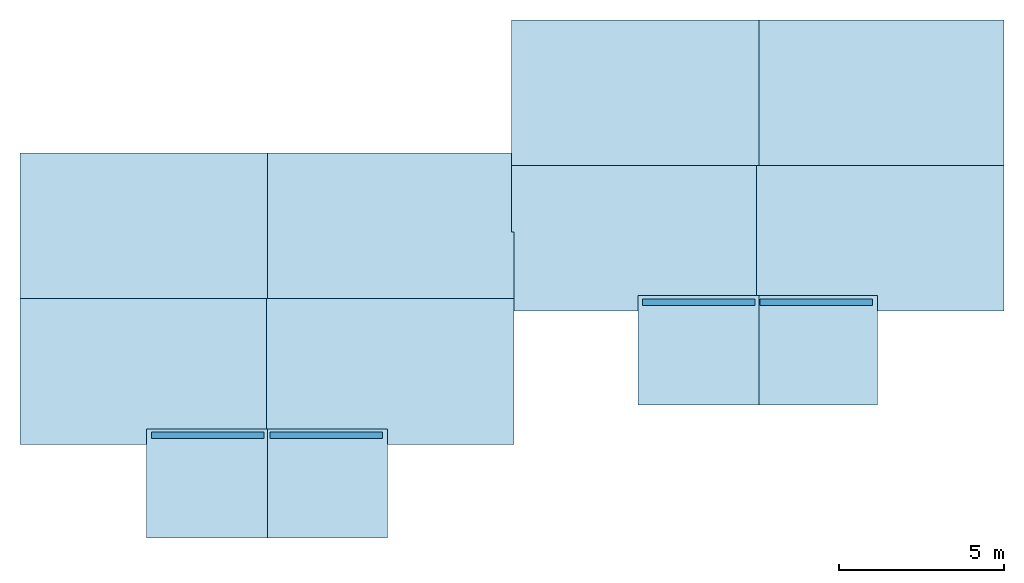
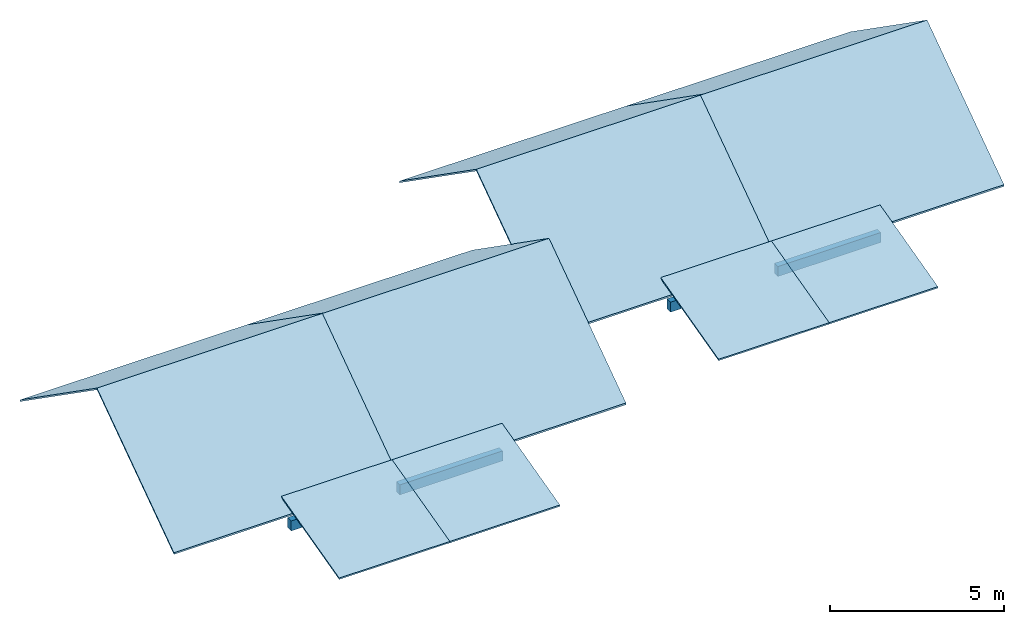
# One storey: 12 slabs, 4 beams, 8 elements without a shape of their own.
"""IFC2X3 building model written with IfcOpenShell, lengths in metres."""

from ifc_helpers import new_model, entity, si_unit, converted_unit, derived_unit, money_unit, direction, frame, frame_2d, origin_with_axes, place, context, subcontext, project, spatial, polyline, rectangle, outline, extrude, material, layer, layer_set, layer_usage, type_object, element, aggregate, save


model = new_model("IFC2X3")

# Units and contexts
model_context = context("Model", 3, precision=1e-05, world=origin_with_axes(), true_north=direction((0.0, 1.0)))
body_context = subcontext(model_context, "Body", "Model", "MODEL_VIEW")
ifc_project = project(units=[si_unit("LENGTHUNIT", "METRE"), si_unit("AREAUNIT", "SQUARE_METRE"), si_unit("VOLUMEUNIT", "CUBIC_METRE"), converted_unit("PLANEANGLEUNIT", "DEGREE", entity("IfcPlaneAngleMeasure", 0.0174532925199), si_unit("PLANEANGLEUNIT", "RADIAN"), dimensions=[0, 0, 0, 0, 0, 0, 0]), si_unit("SOLIDANGLEUNIT", "STERADIAN"), money_unit("CHF"), converted_unit("TIMEUNIT", "Year", entity("IfcTimeMeasure", 31556926.0), si_unit("TIMEUNIT", "SECOND"), dimensions=[0, 0, 1, 0, 0, 0, 0]), si_unit("MASSUNIT", "GRAM", prefix="KILO"), si_unit("THERMODYNAMICTEMPERATUREUNIT", "DEGREE_CELSIUS"), si_unit("LUMINOUSINTENSITYUNIT", "LUMEN"), si_unit("ENERGYUNIT", "JOULE", prefix="MEGA"), derived_unit("THERMALCONDUCTANCEUNIT", [(si_unit("POWERUNIT", "WATT"), 1), (si_unit("LENGTHUNIT", "METRE"), -1), (si_unit("THERMODYNAMICTEMPERATUREUNIT", "KELVIN"), -1)]), derived_unit("SPECIFICHEATCAPACITYUNIT", [(si_unit("ENERGYUNIT", "JOULE"), 1), (si_unit("MASSUNIT", "GRAM", prefix="KILO"), -1), (si_unit("THERMODYNAMICTEMPERATUREUNIT", "KELVIN"), -1)]), derived_unit("MASSDENSITYUNIT", [(si_unit("MASSUNIT", "GRAM", prefix="KILO"), 1), (si_unit("VOLUMEUNIT", "CUBIC_METRE"), -1)])], contexts=[model_context])

# Site, building, storey
site_placement = place(None, origin_with_axes())
site = spatial("IfcSite", under=ifc_project, at=site_placement, CompositionType="ELEMENT")
building_placement = place(site_placement, origin_with_axes())
building = spatial("IfcBuilding", under=site, at=building_placement, CompositionType="ELEMENT")
storey_placement = place(building_placement, frame((0.0, 0.0, 5.64), z_axis=(0.0, 0.0, 1.0), x_axis=(1.0, 0.0, 0.0)))
storey = spatial("IfcBuildingStorey", under=building, at=storey_placement, CompositionType="ELEMENT", Elevation=5.64)

# Beams
ifc_material_1 = material()
beam_type = type_object("IfcBeamType", PredefinedType="BEAM")
for number, where, z_axis, x_axis in (
    (1, (83.6537189554, 84.047523968, 0.07), (0.0, 0.0, 1.0), (0.0, 1.0, 0.0)),
    (2, (83.804085775, 84.047523968, 0.07), (0.0, 0.0, 1.0), (0.0, -1.0, 0.0)),
    (3, (68.931926364, 80.0077566782, 0.07), (0.0, 0.0, 1.0), (0.0, -1.0, 0.0)),
    (4, (68.737326364, 80.0077566782, 0.07), (0.0, 0.0, 1.0), (0.0, 1.0, 0.0)),
):
    element("IfcBeam", number, at=place(storey_placement, frame(where, z_axis=z_axis, x_axis=x_axis)), inside=storey, type_object=beam_type, material=ifc_material_1, ObjectType="BEAM", context=body_context, shape_type="SweptSolid", body=[
        extrude(rectangle(XDim=0.35, YDim=0.2, at=frame_2d((-0.175, 0.0), x_axis=(1.0, 0.0))), frame((0.0, 0.0, 0.0), z_axis=(0.0, 1.0, 0.0), x_axis=(0.0, 0.0, 1.0)), (0.0, 0.0, 1.0), 3.4154),
    ])

# Roof, slabs
roof_1_placement = place(storey_placement, frame((0.0, 0.0, -5.64), z_axis=(0.0, 0.0, 1.0), x_axis=(1.0, 0.0, 0.0)))
roof_1 = element("IfcRoof", 5, at=roof_1_placement, inside=storey, ShapeType="NOTDEFINED")
ifc_material_2 = material()
ifc_layer = layer(ifc_material_2, 0.05, ventilated="UNKNOWN")
ifc_layer_set = layer_set([ifc_layer])
ifc_layer_usage_1 = layer_usage(ifc_layer_set, "AXIS3", "NEGATIVE", 0.05)
slab_type = type_object("IfcSlabType", PredefinedType="ROOF")
slab_1_placement = place(roof_1_placement, frame((76.3328893125, 86.3677566782, 7.58242752871), z_axis=(0.0, 0.0, 1.0), x_axis=(-1.0, 0.0, 0.0)))
slab_1 = element("IfcSlab", 6, at=slab_1_placement, type_object=slab_type, material=ifc_layer_usage_1, PredefinedType="ROOF", context=body_context, shape_type="SweptSolid", body=[
    extrude(outline(polyline([(7.51864635834, 2.69791184116), (0.0, 2.69791184116), (0.0, -2.69791184116), (7.51864635834, -2.69791184116), (7.51864635834, 2.69791184116)])), frame((0.0, 0.0, 0.0), z_axis=(0.0, -0.573576436351, 0.819152044289), x_axis=(1.0, 0.0, 0.0)), (0.0, 0.573576436351, 0.819152044289), 0.0610387294381),
])
ifc_layer_usage_2 = layer_usage(ifc_layer_set, "AXIS3", "NEGATIVE", 0.05)
slab_2_placement = place(roof_1_placement, frame((68.8142429542, 81.9477566782, 7.58242752871), z_axis=(0.0, 0.0, 1.0), x_axis=(1.0, 0.0, 0.0)))
slab_2 = element("IfcSlab", 7, at=slab_2_placement, type_object=slab_type, material=ifc_layer_usage_2, PredefinedType="ROOF", context=body_context, shape_type="SweptSolid", body=[
    extrude(outline(polyline([(0.0, 2.69791184116), (0.0, -2.69791184116), (7.51864635834, -2.69791184116), (7.51864635834, 2.69791184116), (0.0, 2.69791184116)])), frame((0.0, 0.0, 0.0), z_axis=(0.0, -0.573576436351, 0.819152044289), x_axis=(1.0, 0.0, 0.0)), (0.0, 0.573576436351, 0.819152044289), 0.0610387294381),
])
aggregate(roof_1, [slab_1, slab_2])

# Roof, slab
roof_2_placement = place(storey_placement, frame((0.0, 0.0, -5.64), z_axis=(0.0, 0.0, 1.0), x_axis=(1.0, 0.0, 0.0)))
roof_2 = element("IfcRoof", 8, at=roof_2_placement, inside=storey, ShapeType="NOTDEFINED")
ifc_layer_usage_3 = layer_usage(ifc_layer_set, "AXIS3", "NEGATIVE", 0.05)
slab_3_placement = place(roof_2_placement, frame((68.8242429542, 78.5477566782, 5.96653516752), z_axis=(0.0, 0.0, 1.0), x_axis=(1.0, 0.0, 0.0)))
slab_3 = element("IfcSlab", 9, at=slab_3_placement, type_object=slab_type, material=ifc_layer_usage_3, PredefinedType="ROOF", context=body_context, shape_type="SweptSolid", body=[
    extrude(outline(polyline([(3.67038340979, -1.71392305811), (3.67038340979, 1.71392305811), (0.0, 1.71392305811), (0.0, -1.71392305811), (3.67038340979, -1.71392305811)])), frame((0.0, 0.0, 0.0), z_axis=(0.0, -0.248864828268, 0.968538227047), x_axis=(1.0, 0.0, 0.0)), (0.0, 0.248864828268, 0.968538227047), 0.0516241884974),
])
aggregate(roof_2, [slab_3])

# Roof, slabs
roof_3_placement = place(storey_placement, frame((0.0, 0.0, -5.64), z_axis=(0.0, 0.0, 1.0), x_axis=(1.0, 0.0, 0.0)))
roof_3 = element("IfcRoof", 10, at=roof_3_placement, inside=storey, ShapeType="NOTDEFINED")
ifc_layer_usage_4 = layer_usage(ifc_layer_set, "AXIS3", "NEGATIVE", 0.05)
slab_4_placement = place(roof_3_placement, frame((68.8550097738, 86.3677566782, 7.58242752871), z_axis=(0.0, 0.0, 1.0), x_axis=(-1.0, 0.0, 0.0)))
slab_4 = element("IfcSlab", 11, at=slab_4_placement, type_object=slab_type, material=ifc_layer_usage_4, PredefinedType="ROOF", context=body_context, shape_type="SweptSolid", body=[
    extrude(outline(polyline([(0.0, 2.69791184116), (0.0, -2.69791184116), (7.51864635834, -2.69791184116), (7.51864635834, 2.69791184116), (0.0, 2.69791184116)])), frame((0.0, 0.0, 0.0), z_axis=(0.0, -0.573576436351, 0.819152044289), x_axis=(1.0, 0.0, 0.0)), (0.0, 0.573576436351, 0.819152044289), 0.0610387294381),
])
ifc_layer_usage_5 = layer_usage(ifc_layer_set, "AXIS3", "NEGATIVE", 0.05)
slab_5_placement = place(roof_3_placement, frame((61.3363634154, 81.9477566782, 7.58242752871), z_axis=(0.0, 0.0, 1.0), x_axis=(1.0, 0.0, 0.0)))
slab_5 = element("IfcSlab", 12, at=slab_5_placement, type_object=slab_type, material=ifc_layer_usage_5, PredefinedType="ROOF", context=body_context, shape_type="SweptSolid", body=[
    extrude(outline(polyline([(7.51864635834, 2.69791184116), (0.0, 2.69791184116), (0.0, -2.69791184116), (7.51864635834, -2.69791184116), (7.51864635834, 2.69791184116)])), frame((0.0, 0.0, 0.0), z_axis=(0.0, -0.573576436351, 0.819152044289), x_axis=(1.0, 0.0, 0.0)), (0.0, 0.573576436351, 0.819152044289), 0.0610387294381),
])
aggregate(roof_3, [slab_4, slab_5])

# Roof, slab
roof_4_placement = place(storey_placement, frame((0.0, 0.0, -5.64), z_axis=(0.0, 0.0, 1.0), x_axis=(1.0, 0.0, 0.0)))
roof_4 = element("IfcRoof", 13, at=roof_4_placement, inside=storey, ShapeType="NOTDEFINED")
ifc_layer_usage_6 = layer_usage(ifc_layer_set, "AXIS3", "NEGATIVE", 0.05)
slab_6_placement = place(roof_4_placement, frame((65.174626364, 78.5477566782, 5.96653516752), z_axis=(0.0, 0.0, 1.0), x_axis=(1.0, 0.0, 0.0)))
slab_6 = element("IfcSlab", 14, at=slab_6_placement, type_object=slab_type, material=ifc_layer_usage_6, PredefinedType="ROOF", context=body_context, shape_type="SweptSolid", body=[
    extrude(outline(polyline([(0.0, 1.71392305811), (0.0, -1.71392305811), (3.67038340979, -1.71392305811), (3.67038340979, 1.71392305811), (0.0, 1.71392305811)])), frame((0.0, 0.0, 0.0), z_axis=(0.0, -0.248864828268, 0.968538227047), x_axis=(1.0, 0.0, 0.0)), (0.0, 0.248864828268, 0.968538227047), 0.0516241884974),
])
aggregate(roof_4, [slab_6])

# Roof, slabs
roof_5_placement = place(storey_placement, frame((0.0, 0.0, -5.64), z_axis=(0.0, 0.0, 1.0), x_axis=(1.0, 0.0, 0.0)))
roof_5 = element("IfcRoof", 15, at=roof_5_placement, inside=storey, ShapeType="NOTDEFINED")
ifc_layer_usage_7 = layer_usage(ifc_layer_set, "AXIS3", "NEGATIVE", 0.05)
slab_7_placement = place(roof_5_placement, frame((91.2050487235, 90.407523968, 7.58242752871), z_axis=(0.0, 0.0, 1.0), x_axis=(-1.0, 0.0, 0.0)))
slab_7 = element("IfcSlab", 16, at=slab_7_placement, type_object=slab_type, material=ifc_layer_usage_7, PredefinedType="ROOF", context=body_context, shape_type="SweptSolid", body=[
    extrude(outline(polyline([(7.51864635834, 2.69791184116), (0.0, 2.69791184116), (0.0, -2.69791184116), (7.51864635834, -2.69791184116), (7.51864635834, 2.69791184116)])), frame((0.0, 0.0, 0.0), z_axis=(0.0, -0.573576436351, 0.819152044289), x_axis=(1.0, 0.0, 0.0)), (0.0, 0.573576436351, 0.819152044289), 0.0610387294381),
])
ifc_layer_usage_8 = layer_usage(ifc_layer_set, "AXIS3", "NEGATIVE", 0.05)
slab_8_placement = place(roof_5_placement, frame((83.6864023652, 85.987523968, 7.58242752871), z_axis=(0.0, 0.0, 1.0), x_axis=(1.0, 0.0, 0.0)))
slab_8 = element("IfcSlab", 17, at=slab_8_placement, type_object=slab_type, material=ifc_layer_usage_8, PredefinedType="ROOF", context=body_context, shape_type="SweptSolid", body=[
    extrude(outline(polyline([(0.0, 2.69791184116), (0.0, -2.69791184116), (7.51864635834, -2.69791184116), (7.51864635834, 2.69791184116), (0.0, 2.69791184116)])), frame((0.0, 0.0, 0.0), z_axis=(0.0, -0.573576436351, 0.819152044289), x_axis=(1.0, 0.0, 0.0)), (0.0, 0.573576436351, 0.819152044289), 0.0610387294381),
])
aggregate(roof_5, [slab_7, slab_8])

# Roof, slab
roof_6_placement = place(storey_placement, frame((0.0, 0.0, -5.64), z_axis=(0.0, 0.0, 1.0), x_axis=(1.0, 0.0, 0.0)))
roof_6 = element("IfcRoof", 18, at=roof_6_placement, inside=storey, ShapeType="NOTDEFINED")
ifc_layer_usage_9 = layer_usage(ifc_layer_set, "AXIS3", "NEGATIVE", 0.05)
slab_9_placement = place(roof_6_placement, frame((83.6964023652, 82.587523968, 5.96653516752), z_axis=(0.0, 0.0, 1.0), x_axis=(1.0, 0.0, 0.0)))
slab_9 = element("IfcSlab", 19, at=slab_9_placement, type_object=slab_type, material=ifc_layer_usage_9, PredefinedType="ROOF", context=body_context, shape_type="SweptSolid", body=[
    extrude(outline(polyline([(3.67038340979, -1.71392305811), (3.67038340979, 1.71392305811), (0.0, 1.71392305811), (0.0, -1.71392305811), (3.67038340979, -1.71392305811)])), frame((0.0, 0.0, 0.0), z_axis=(0.0, -0.248864828268, 0.968538227047), x_axis=(1.0, 0.0, 0.0)), (0.0, 0.248864828268, 0.968538227047), 0.0516241884974),
])
aggregate(roof_6, [slab_9])

# Roof, slabs
roof_7_placement = place(storey_placement, frame((0.0, 0.0, -5.64), z_axis=(0.0, 0.0, 1.0), x_axis=(1.0, 0.0, 0.0)))
roof_7 = element("IfcRoof", 20, at=roof_7_placement, inside=storey, ShapeType="NOTDEFINED")
ifc_layer_usage_10 = layer_usage(ifc_layer_set, "AXIS3", "NEGATIVE", 0.05)
slab_10_placement = place(roof_7_placement, frame((83.7714023652, 90.407523968, 7.58242752871), z_axis=(0.0, 0.0, 1.0), x_axis=(-1.0, 0.0, 0.0)))
slab_10 = element("IfcSlab", 21, at=slab_10_placement, type_object=slab_type, material=ifc_layer_usage_10, PredefinedType="ROOF", context=body_context, shape_type="SweptSolid", body=[
    extrude(outline(polyline([(0.0, 2.69791184116), (0.0, -2.69791184116), (7.51864635834, -2.69791184116), (7.51864635834, 2.69791184116), (0.0, 2.69791184116)])), frame((0.0, 0.0, 0.0), z_axis=(0.0, -0.573576436351, 0.819152044289), x_axis=(1.0, 0.0, 0.0)), (0.0, 0.573576436351, 0.819152044289), 0.0610387294381),
])
ifc_layer_usage_11 = layer_usage(ifc_layer_set, "AXIS3", "NEGATIVE", 0.05)
slab_11_placement = place(roof_7_placement, frame((76.2527560068, 85.987523968, 7.58242752871), z_axis=(0.0, 0.0, 1.0), x_axis=(1.0, 0.0, 0.0)))
slab_11 = element("IfcSlab", 22, at=slab_11_placement, type_object=slab_type, material=ifc_layer_usage_11, PredefinedType="ROOF", context=body_context, shape_type="SweptSolid", body=[
    extrude(outline(polyline([(7.51864635834, 2.69791184116), (0.0, 2.69791184116), (0.0, -2.69791184116), (7.51864635834, -2.69791184116), (7.51864635834, 2.69791184116)])), frame((0.0, 0.0, 0.0), z_axis=(0.0, -0.573576436351, 0.819152044289), x_axis=(1.0, 0.0, 0.0)), (0.0, 0.573576436351, 0.819152044289), 0.0610387294381),
])
aggregate(roof_7, [slab_10, slab_11])

# Roof, slab
roof_8_placement = place(storey_placement, frame((0.0, 0.0, -5.64), z_axis=(0.0, 0.0, 1.0), x_axis=(1.0, 0.0, 0.0)))
roof_8 = element("IfcRoof", 23, at=roof_8_placement, inside=storey, ShapeType="NOTDEFINED")
ifc_layer_usage_12 = layer_usage(ifc_layer_set, "AXIS3", "NEGATIVE", 0.05)
slab_12_placement = place(roof_8_placement, frame((80.0910189554, 82.587523968, 5.96653516752), z_axis=(0.0, 0.0, 1.0), x_axis=(1.0, 0.0, 0.0)))
slab_12 = element("IfcSlab", 24, at=slab_12_placement, type_object=slab_type, material=ifc_layer_usage_12, PredefinedType="ROOF", context=body_context, shape_type="SweptSolid", body=[
    extrude(outline(polyline([(0.0, 1.71392305811), (0.0, -1.71392305811), (3.67038340979, -1.71392305811), (3.67038340979, 1.71392305811), (0.0, 1.71392305811)])), frame((0.0, 0.0, 0.0), z_axis=(0.0, -0.248864828268, 0.968538227047), x_axis=(1.0, 0.0, 0.0)), (0.0, 0.248864828268, 0.968538227047), 0.0516241884974),
])
aggregate(roof_8, [slab_12])

save(model, "model.ifc")
